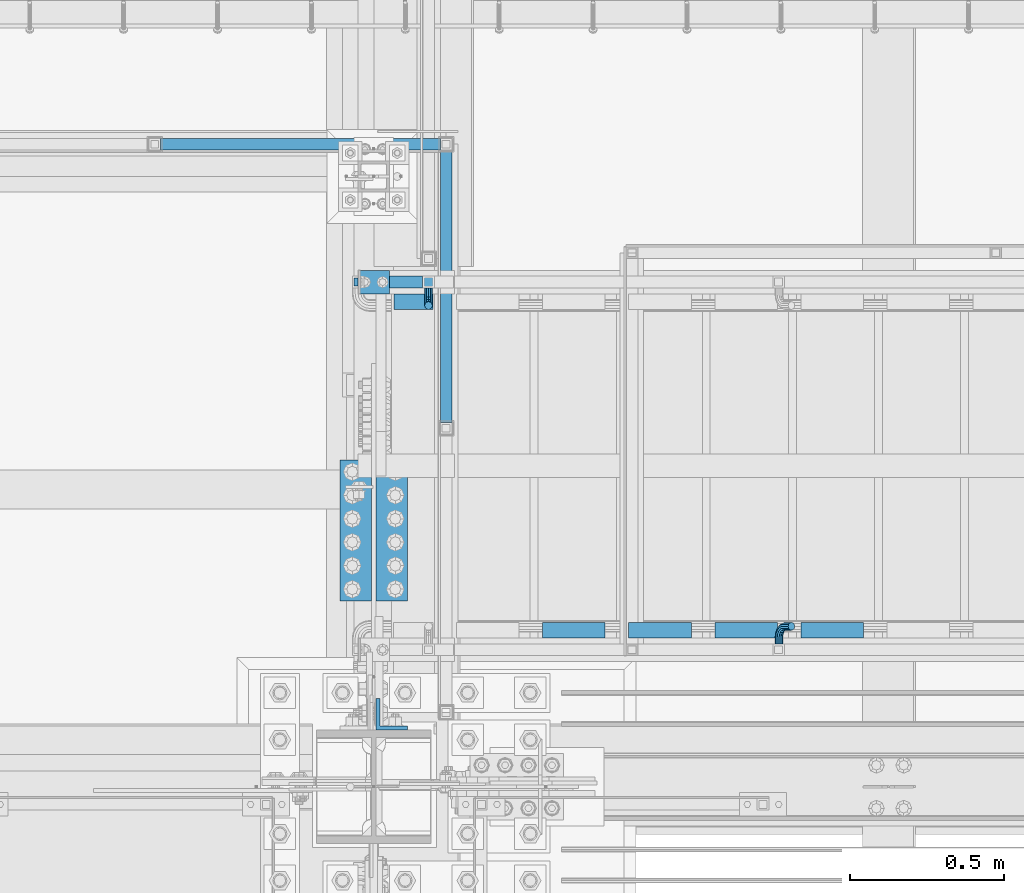
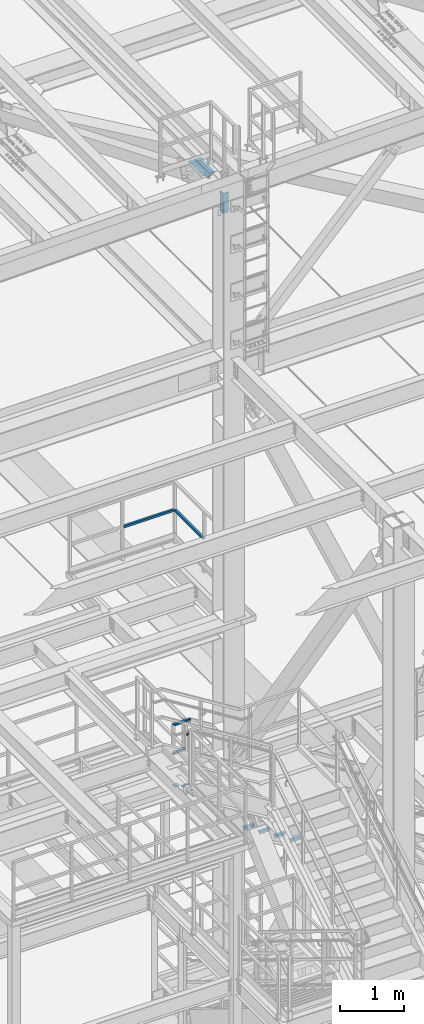
# One storey, part 2131 of 3843: 15 beams, 5 elements without a shape of their own.
"""IFC2X3 building model written with IfcOpenShell, lengths in millimetres."""

from ifc_helpers import new_model, si_unit, frame, origin_with_axes, place, context, subcontext, project, spatial, faceted_brep, material, type_object, element, aggregate, save


model = new_model("IFC2X3")

# Units and contexts
model_context = context("Model", 3, precision=1e-05, world=origin_with_axes())
body_context = subcontext(model_context, "Body", "Model", "MODEL_VIEW")
ifc_project = project(units=[si_unit("LENGTHUNIT", "METRE", prefix="MILLI"), si_unit("AREAUNIT", "SQUARE_METRE"), si_unit("VOLUMEUNIT", "CUBIC_METRE"), si_unit("MASSUNIT", "GRAM", prefix="KILO"), si_unit("TIMEUNIT", "SECOND"), si_unit("PLANEANGLEUNIT", "RADIAN"), si_unit("SOLIDANGLEUNIT", "STERADIAN"), si_unit("THERMODYNAMICTEMPERATUREUNIT", "DEGREE_CELSIUS"), si_unit("LUMINOUSINTENSITYUNIT", "LUMEN")], contexts=[model_context])

# Site, building, storey
site_placement = place(None, origin_with_axes())
site = spatial("IfcSite", under=ifc_project, at=site_placement, CompositionType="ELEMENT")
building_placement = place(site_placement, origin_with_axes())
building = spatial("IfcBuilding", under=site, at=building_placement, Name="Undefined", CompositionType="ELEMENT")
storey_placement = place(building_placement, origin_with_axes())
storey = spatial("IfcBuildingStorey", under=building, at=storey_placement, Name="Undefined", CompositionType="ELEMENT", Elevation=0.0)

# Assembly, beams
assembly_1_placement = place(storey_placement, origin_with_axes())
assembly_1 = element("IfcElementAssembly", 1, at=assembly_1_placement, inside=storey, Name="RAIL", AssemblyPlace="NOTDEFINED", PredefinedType="RIGID_FRAME")
ifc_material_1 = material()
beam_type_1 = type_object("IfcBeamType", Name="HSS1-1/2X1-1/2X1/4", PredefinedType="NOTDEFINED")
beam_1_placement = place(assembly_1_placement, frame((55219.6000061035, 27701.8747862042, 38099.9999983618), z_axis=(0.0, 0.0, 1.0), x_axis=(1.0, 0.0, 0.0)))
beam_1 = element("IfcBeam", 2, at=beam_1_placement, type_object=beam_type_1, material=ifc_material_1, Name="RAIL", ObjectType="HSS1-1/2X1-1/2X1/4", context=body_context, shape_type="Brep", body=[
    faceted_brep([(927.100006103494, -19.0499999999956, 19.0499992350015), (927.100006103494, -19.0499992350015, -19.0499992350015), (927.100006103494, 19.0499992350015, -19.0499992350015), (927.100006103494, 19.0499992350015, 19.0499992350015), (927.099999330007, -12.6999993299978, 12.6999993300014), (927.099999330007, 12.6999993299978, 12.6999993300014), (927.099999330007, 12.6999993299978, -12.6999993300014), (927.099999330007, -12.6999993299978, -12.6999993300014), (19.0499992350015, 19.0499992350015, -19.0499992350015), (19.0499992350015, 19.0499992350015, 19.0499992350015), (19.0499992350015, -19.0499992350015, 19.0499992350015), (19.0499992350015, -19.0499992350015, -19.0499992350015), (19.0499992350015, 12.6999993299978, 12.6999993299978), (19.0499992350015, -12.6999993299978, 12.6999993299978), (19.0499992350015, -12.6999993299978, -12.6999993299978), (19.0499992350015, 12.6999993299978, -12.6999993299978)], [[[0, 1, 2, 3], [4, 5, 6, 7]], [[8, 9, 3, 2]], [[9, 10, 0, 3]], [[10, 11, 1, 0]], [[11, 8, 2, 1]], [[11, 10, 9, 8], [12, 13, 14, 15]], [[14, 13, 4, 7]], [[15, 14, 7, 6]], [[12, 15, 6, 5]], [[13, 12, 5, 4]]]),
])
beam_2_placement = place(assembly_1_placement, frame((56165.7500122069, 26779.5373931012, 38099.9999983618), z_axis=(0.0, 0.0, 1.0), x_axis=(0.0, 1.0, 0.0)))
beam_2 = element("IfcBeam", 3, at=beam_2_placement, type_object=beam_type_1, material=ifc_material_1, Name="RAIL", ObjectType="HSS1-1/2X1-1/2X1/4", context=body_context, shape_type="Brep", body=[
    faceted_brep([(903.287393102968, -19.0500000001557, 19.0499992350015), (903.287393102968, -19.0499992350015, -19.0499992350015), (903.287393102968, 19.0499992350015, -19.0499992350015), (903.287393102968, 19.0499992350015, 19.0499992350015), (903.287393102968, -12.6999993299978, 12.6999993299978), (903.287393102968, 12.6999993299978, 12.6999993299978), (903.287393102968, 12.6999993299978, -12.6999993299978), (903.287393102968, -12.6999993299978, -12.6999993299978), (19.0499992350015, 19.0499992350015, -19.0499992350015), (19.0499992350015, 19.0499992350015, 19.0499992350015), (19.0499992350015, -19.0499992350015, 19.0499992350015), (19.0499992350015, -19.0499992350015, -19.0499992350015), (19.0499992350015, 12.6999993299978, 12.6999993299978), (19.0499992350015, -12.6999993299978, 12.6999993299978), (19.0499992350015, -12.6999993299978, -12.6999993299978), (19.0499992350015, 12.6999993299978, -12.6999993299978)], [[[0, 1, 2, 3], [4, 5, 6, 7]], [[8, 9, 3, 2]], [[9, 10, 0, 3]], [[10, 11, 1, 0]], [[11, 8, 2, 1]], [[11, 10, 9, 8], [12, 13, 14, 15]], [[14, 13, 4, 7]], [[15, 14, 7, 6]], [[12, 15, 6, 5]], [[13, 12, 5, 4]]]),
])
aggregate(assembly_1, [beam_1, beam_2])

assembly_2_placement = place(storey_placement, origin_with_axes())
assembly_2 = element("IfcElementAssembly", 4, at=assembly_2_placement, inside=storey, Name="RAIL", AssemblyPlace="NOTDEFINED", PredefinedType="RIGID_FRAME")
beam_3_placement = place(assembly_2_placement, frame((56108.5999999771, 27254.20000005, 33832.8000002553), z_axis=(0.0, 0.0, 1.0), x_axis=(-1.0, 0.0, 0.0)))
beam_3 = element("IfcBeam", 5, at=beam_3_placement, type_object=beam_type_1, material=ifc_material_1, Name="RAIL", ObjectType="HSS1-1/2X1-1/2X1/4", context=body_context, shape_type="Brep", body=[
    faceted_brep([(19.0499992350015, -19.0499992350015, -19.0499992350015), (19.0499992350015, -19.0499992350015, 19.0499992350015), (19.0499992350015, 19.0499992350015, 19.0499992350015), (19.0499992350015, 19.0499992350015, -19.0499992350015), (19.0499992350015, 12.6999993299978, 12.6999993299978), (19.0499992350015, -12.6999993299978, 12.6999993299978), (19.0499992350015, -12.6999993299978, -12.6999993299978), (19.0499992350015, 12.6999993299978, -12.6999993299978), (247.649999996247, 19.0499992350015, -19.0499992350015), (247.649999996247, -19.0499992350015, -19.0499992350015), (209.550000745963, -19.0499992350015, 19.0499992356708), (209.550000745963, 19.0499992350015, 19.0499992356708), (215.900000654663, -12.6999993300014, 12.6999993306963), (215.900000654663, 12.6999993300014, 12.6999993306963), (241.299999329458, 12.6999993300014, -12.6999993292266), (241.299999329458, -12.6999993300014, -12.6999993292266)], [[[0, 1, 2, 3], [4, 5, 6, 7]], [[8, 9, 0, 3]], [[9, 10, 1, 0]], [[10, 11, 2, 1]], [[11, 8, 3, 2]], [[10, 9, 8, 11], [12, 13, 14, 15]], [[13, 12, 5, 4]], [[14, 13, 4, 7]], [[15, 14, 7, 6]], [[12, 15, 6, 5]]]),
])
beam_4_placement = place(assembly_2_placement, frame((55879.9999999771, 27254.20000005, 34366.20000008), z_axis=(0.0, 0.0, -1.0), x_axis=(1.0, 0.0, 0.0)))
beam_4 = element("IfcBeam", 6, at=beam_4_placement, type_object=beam_type_1, material=ifc_material_1, Name="RAIL", ObjectType="HSS1-1/2X1-1/2X1/4", context=body_context, shape_type="Brep", body=[
    faceted_brep([(-12.6999993309546, 12.6999993299978, -12.6999993299978), (-12.6999993309546, -12.6999993299978, -12.6999993299978), (308.4703350696, -12.6999993300014, -12.6999993290228), (308.4703350696, 12.6999993300014, -12.6999993290228), (12.6999993290483, -12.6999993299978, 12.6999993299978), (301.129664099179, -12.6999993300014, 12.6999993309582), (12.6999993290483, 12.6999993299978, 12.6999993299978), (301.129664099179, 12.6999993300014, 12.6999993309582), (-19.0499992359546, 19.0499992350015, -19.0499992350015), (19.0499992350015, 19.0499992350015, 19.0499992350015), (299.294496287221, 19.0499992350015, 19.0499992359473), (310.305502881565, 19.0499992350015, -19.0499992340192), (19.0499992350015, -19.0499992350015, 19.0499992350015), (299.294496287221, -19.0499992350015, 19.0499992359473), (-19.0499992359546, -19.0499992350015, -19.0499992350015), (310.305502881565, -19.0499992350015, -19.0499992340192)], [[[0, 1, 2, 3]], [[1, 4, 5, 2]], [[4, 6, 7, 5]], [[6, 0, 3, 7]], [[8, 9, 10, 11]], [[9, 12, 13, 10]], [[12, 14, 15, 13]], [[14, 8, 11, 15]], [[13, 15, 11, 10], [5, 7, 3, 2]], [[14, 12, 9, 8], [6, 4, 1, 0]]]),
])

assembly_3_placement = place(storey_placement, origin_with_axes())
assembly_3 = element("IfcElementAssembly", 7, at=assembly_3_placement, inside=storey, Name="STAIR", AssemblyPlace="NOTDEFINED", PredefinedType="RIGID_FRAME")
ifc_material_2 = material(Name="STEEL/A36")
beam_type_2 = type_object("IfcBeamType", PredefinedType="NOTDEFINED")
beam_5_placement = place(assembly_3_placement, frame((55880.0, 27254.2, 33200.9749999995), z_axis=(0.0, 1.0, 0.0), x_axis=(1.0, 0.0, 0.0)))
beam_5 = element("IfcBeam", 8, at=beam_5_placement, type_object=beam_type_2, material=ifc_material_2, Name="PLATE", context=body_context, shape_type="Brep", body=[
    faceted_brep([(0.0, 3.17500000000291, -38.0999999999985), (0.0, 3.17500000000291, 38.0999999999985), (101.60000000002, 3.17500000000291, 38.0999999999985), (101.60000000002, 3.17500000000291, -38.0999999999985), (0.0, -3.17500000000291, 38.0999999999985), (101.60000000002, -3.17500000000291, 38.0999999999985), (0.0, -3.17500000000291, -38.0999999999985), (101.60000000002, -3.17500000000291, -38.0999999999985)], [[[0, 1, 2, 3]], [[1, 4, 5, 2]], [[4, 6, 7, 5]], [[6, 0, 3, 7]], [[5, 7, 3, 2]], [[6, 4, 1, 0]]]),
])
beam_type_3 = type_object("IfcBeamType", Name="L2X2X3/16", PredefinedType="NOTDEFINED")
beam_6_placement = place(assembly_3_placement, frame((55995.8875, 27190.7000000424, 33178.7500000177), z_axis=(0.0, -1.0, 0.0), x_axis=(1.0, 0.0, 0.0)))
beam_6 = element("IfcBeam", 9, at=beam_6_placement, type_object=beam_type_3, material=ifc_material_2, Name="ANGLE", ObjectType="L2X2X3/16", context=body_context, shape_type="Brep", body=[
    faceted_brep([(0.0, 25.4000000000015, -25.4000000000015), (0.0, 25.4000000000015, 25.4000000000015), (127.000000013548, 25.4000000000015, 25.4000000000015), (127.000000013548, 25.4000000000015, -25.4000000000015), (0.0, 20.6375000000007, 25.4000000000015), (127.000000013548, 20.6374999999971, 25.4000000000015), (0.0, 20.6375000000007, -20.6375000000007), (127.000000013548, 20.6374999999971, -20.6375000000007), (0.0, -25.4000000000015, -20.6375000000007), (127.000000013548, -25.4000000000015, -20.6375000000007), (0.0, -25.4000000000015, -25.4000000000015), (127.000000013548, -25.4000000000015, -25.4000000000015)], [[[0, 1, 2, 3]], [[1, 4, 5, 2]], [[4, 6, 7, 5]], [[6, 8, 9, 7]], [[8, 10, 11, 9]], [[10, 0, 3, 11]], [[5, 7, 9, 11, 3, 2]], [[10, 8, 6, 4, 1, 0]]]),
])
beam_7_placement = place(assembly_3_placement, frame((56682.2696627235, 26123.9000000591, 32867.599999978), z_axis=(0.0, 1.0, 0.0), x_axis=(-1.0, 0.0, 0.0)))
beam_7 = element("IfcBeam", 10, at=beam_7_placement, type_object=beam_type_3, material=ifc_material_2, Name="ANGLE", ObjectType="L2X2X3/16", context=body_context, shape_type="Brep", body=[
    faceted_brep([(0.0, 25.4000000000015, -25.4000000000015), (0.0, 25.4000000000015, 25.4000000000015), (203.199999999997, 25.4000000000015, 25.4000000000015), (203.199999999997, 25.4000000000015, -25.4000000000015), (0.0, 20.6375000000007, 25.4000000000015), (203.199999999997, 20.6375000000007, 25.4000000000015), (0.0, 20.6375000000007, -20.6375000000007), (203.199999999997, 20.6375000000007, -20.6375000000007), (0.0, -25.4000000000015, -20.6375000000007), (203.199999999997, -25.4000000000015, -20.6375000000007), (0.0, -25.4000000000015, -25.4000000000015), (203.199999999997, -25.4000000000015, -25.4000000000015)], [[[0, 1, 2, 3]], [[1, 4, 5, 2]], [[4, 6, 7, 5]], [[6, 8, 9, 7]], [[8, 10, 11, 9]], [[10, 0, 3, 11]], [[5, 7, 9, 11, 3, 2]], [[10, 8, 6, 4, 1, 0]]]),
])
beam_8_placement = place(assembly_3_placement, frame((56961.6696627235, 26123.9000000571, 32691.387499978), z_axis=(0.0, 1.0, 0.0), x_axis=(-1.0, 0.0, 0.0)))
beam_8 = element("IfcBeam", 11, at=beam_8_placement, type_object=beam_type_3, material=ifc_material_2, Name="ANGLE", ObjectType="L2X2X3/16", context=body_context, shape_type="Brep", body=[
    faceted_brep([(0.0, 25.4000000000015, -25.4000000000015), (0.0, 25.4000000000015, 25.4000000000015), (203.199999999997, 25.4000000000015, 25.4000000000015), (203.199999999997, 25.4000000000015, -25.4000000000015), (0.0, 20.6375000000007, 25.4000000000015), (203.199999999997, 20.6375000000007, 25.4000000000015), (0.0, 20.6375000000007, -20.6375000000007), (203.199999999997, 20.6375000000007, -20.6375000000007), (0.0, -25.4000000000015, -20.6375000000007), (203.199999999997, -25.4000000000015, -20.6375000000007), (0.0, -25.4000000000015, -25.4000000000015), (203.199999999997, -25.4000000000015, -25.4000000000015)], [[[0, 1, 2, 3]], [[1, 4, 5, 2]], [[4, 6, 7, 5]], [[6, 8, 9, 7]], [[8, 10, 11, 9]], [[10, 0, 3, 11]], [[5, 7, 9, 11, 3, 2]], [[10, 8, 6, 4, 1, 0]]]),
])
beam_9_placement = place(assembly_3_placement, frame((57241.0696627235, 26123.900000055, 32515.174999978), z_axis=(0.0, 1.0, 0.0), x_axis=(-1.0, 0.0, 0.0)))
beam_9 = element("IfcBeam", 12, at=beam_9_placement, type_object=beam_type_3, material=ifc_material_2, Name="ANGLE", ObjectType="L2X2X3/16", context=body_context, shape_type="Brep", body=[
    faceted_brep([(0.0, 25.4000000000015, -25.4000000000015), (0.0, 25.4000000000015, 25.4000000000015), (203.199999999997, 25.4000000000015, 25.4000000000015), (203.199999999997, 25.4000000000015, -25.4000000000015), (0.0, 20.6375000000007, 25.4000000000015), (203.199999999997, 20.6375000000007, 25.4000000000015), (0.0, 20.6375000000007, -20.6375000000007), (203.199999999997, 20.6375000000007, -20.6375000000007), (0.0, -25.4000000000015, -20.6375000000007), (203.199999999997, -25.4000000000015, -20.6375000000007), (0.0, -25.4000000000015, -25.4000000000015), (203.199999999997, -25.4000000000015, -25.4000000000015)], [[[0, 1, 2, 3]], [[1, 4, 5, 2]], [[4, 6, 7, 5]], [[6, 8, 9, 7]], [[8, 10, 11, 9]], [[10, 0, 3, 11]], [[5, 7, 9, 11, 3, 2]], [[10, 8, 6, 4, 1, 0]]]),
])
beam_10_placement = place(assembly_3_placement, frame((57520.4696627267, 26123.9000000536, 32338.9624999776), z_axis=(0.0, 1.0, 0.0), x_axis=(-1.0, 0.0, 0.0)))
beam_10 = element("IfcBeam", 13, at=beam_10_placement, type_object=beam_type_3, material=ifc_material_2, Name="ANGLE", ObjectType="L2X2X3/16", context=body_context, shape_type="Brep", body=[
    faceted_brep([(0.0, 25.4000000000015, -25.4000000000015), (0.0, 25.4000000000015, 25.4000000000015), (203.199999999997, 25.4000000000015, 25.4000000000015), (203.199999999997, 25.4000000000015, -25.4000000000015), (0.0, 20.6375000000007, 25.4000000000015), (203.199999999997, 20.6375000000007, 25.4000000000015), (0.0, 20.6375000000007, -20.6375000000007), (203.199999999997, 20.6375000000007, -20.6375000000007), (0.0, -25.4000000000015, -20.6375000000007), (203.199999999997, -25.4000000000015, -20.6375000000007), (0.0, -25.4000000000015, -25.4000000000015), (203.199999999997, -25.4000000000015, -25.4000000000015)], [[[0, 1, 2, 3]], [[1, 4, 5, 2]], [[4, 6, 7, 5]], [[6, 8, 9, 7]], [[8, 10, 11, 9]], [[10, 0, 3, 11]], [[5, 7, 9, 11, 3, 2]], [[10, 8, 6, 4, 1, 0]]]),
])
aggregate(assembly_3, [beam_6, beam_5, beam_7, beam_8, beam_9, beam_10])

# Beam
beam_type_4 = type_object("IfcBeamType", PredefinedType="NOTDEFINED")
beam_11_placement = place(assembly_2_placement, frame((56108.6000003381, 27235.15000005, 34118.55), z_axis=(-1.0, 0.0, 0.0), x_axis=(0.0, -1.0, 0.0)))
beam_11 = element("IfcBeam", 14, at=beam_11_placement, type_object=beam_type_4, material=ifc_material_2, Name="BRACKET ARM", context=body_context, shape_type="Brep", body=[
    faceted_brep([(0.0, -12.6999999999971, 0.0), (0.0, -10.9985226280696, -6.34999999999854), (19.0500015258731, -10.9985226280623, -6.34999999999854), (19.0500015258731, -12.6999999999971, -6.33008312433958e-10), (0.0, -6.35000000000582, -10.9985226280623), (19.0500015258731, -6.34999999999854, -10.9985226280623), (0.0, 0.0, -12.6999999999971), (19.0500015258731, 0.0, -12.6999999999971), (0.0, 6.35000000000582, -10.9985226280623), (19.0500015258731, 6.34999999999854, -10.9985226280623), (0.0, 10.9985226280696, -6.34999999999854), (19.0500015258731, 10.9985226280623, -6.34999999999854), (0.0, 12.6999999999971, 0.0), (19.0500015258731, 12.6999999999971, 0.0), (0.0, 10.9985226280696, 6.34999999999854), (19.0500015258731, 10.9985226280623, 6.34999999999854), (0.0, 6.35000000000582, 10.9985226280623), (19.0500015258731, 6.34999999999854, 10.9985226280623), (0.0, 0.0, 12.6999999999971), (19.0500015258731, 0.0, 12.6999999999971), (0.0, -6.35000000000582, 10.9985226280623), (19.0500015258731, -6.34999999999854, 10.9985226280623), (0.0, -10.9985226280696, 6.34999999999854), (19.0500015258731, -10.9985226280623, 6.34999999999854), (38.4903193060891, -8.8330803677236, -3.34694050252438e-10), (37.8391921052389, -7.26112024908798, 6.34999999974389), (36.0602795104642, -2.96644533684594, 10.9985226280041), (33.6302397149266, 2.90018969451194, 12.7000000002226), (31.2001999194181, 8.76682472604443, 10.9985226285644), (29.4212873247307, 13.061499638774, 6.35000000070431), (28.7701601240115, 14.6334597580644, 7.78527464717627e-10), (29.4212873248762, 13.0614996394288, -6.34999999929278), (31.2001999196509, 8.76682472718676, -10.9985226275603), (33.6302397151885, 2.90018969582889, -12.6999999997788), (36.0602795106824, -2.96644533571089, -10.9985226281206), (37.8391921053699, -7.26112024843314, -6.35000000026048), (53.7678987435793, 3.38210125690239, -6.3499999994383), (54.9710249311902, 2.17897506880399, 5.0931703299284e-10), (50.4808968708676, 6.66910312997061, -10.9985226273784), (45.9907688103704, 11.1592311906061, -12.6999999991458), (41.5006407498004, 15.6493592510378, -10.9985226270364), (38.213638876914, 18.9363611235749, -6.34999999884167), (37.0105126890558, 20.1394873109457, 1.20053300634027e-09), (38.2136388766667, 18.9363611228473, 6.35000000115542), (41.5006407493784, 15.6493592497718, 10.9985226290883), (45.9907688098756, 11.1592311891436, 12.7000000008557), (50.4808968704456, 6.66910312870459, 10.9985226287463), (53.7678987433319, 3.38210125617479, 6.35000000055879), (64.4111202489148, 19.3108078951118, -6.34999999821594), (65.9830803677178, 18.6596806939051, 1.77533365786076e-09), (60.1164453365491, 21.0897204901557, -10.9985226262725), (54.2498103051475, 23.5197602857806, -12.6999999981927), (48.3831752736587, 25.9498000811873, -10.9985226262434), (44.0885003610601, 27.7287126756128, -6.34999999817228), (42.516540241937, 28.3798398759754, 1.83354131877422e-09), (44.08850036074, 27.7287126747688, 6.35000000183209), (48.3831752731057, 25.9498000797321, 10.9985226298813), (54.2498103045073, 23.5197602840999, 12.7000000018088), (60.1164453359961, 21.0897204886933, 10.9985226298522), (64.4111202485947, 19.3108078942678, 6.35000000178115), (68.1485226282239, 38.0999984746086, -6.3499999967753), (69.8499999999913, 38.0999984741211, 2.92493496090174e-09), (63.500000000291, 38.0999984749651, -10.9985226249628), (57.1500000003434, 38.0999984750961, -12.6999999970722), (50.8000000002939, 38.0999984749651, -10.998522625312), (46.1514773720992, 38.0999984746086, -6.34999999737192), (44.4499999999971, 38.0999984741211, 2.58296495303512e-09), (46.1514773717645, 38.0999984736336, 6.35000000262517), (50.7999999996973, 38.0999984732771, 10.9985226308127), (57.1499999996449, 38.0999984731461, 12.700000002922), (63.4999999996944, 38.0999984732771, 10.9985226311619), (68.1485226278892, 38.0999984736336, 6.35000000322179), (68.1485226280638, 76.2000000002372, -6.34999999414867), (69.8499999999913, 76.199999999757, 5.84986992180347e-09), (63.5, 76.200000000601, -10.9985226222125), (57.1499999999942, 76.2000000007247, -12.6999999941472), (50.7999999999884, 76.200000000601, -10.9985226222125), (46.1514773719246, 76.2000000002372, -6.34999999414867), (44.4499999999971, 76.199999999757, 5.84986992180347e-09), (46.1514773719246, 76.1999999992695, 6.35000000584841), (50.7999999999884, 76.1999999989057, 10.9985226339122), (57.1499999999942, 76.199999998782, 12.700000005847), (63.5, 76.1999999989057, 10.9985226339122), (68.1485226280638, 76.1999999992695, 6.35000000584841)], [[[0, 1, 2, 3]], [[1, 4, 5, 2]], [[4, 6, 7, 5]], [[6, 8, 9, 7]], [[8, 10, 11, 9]], [[10, 12, 13, 11]], [[12, 14, 15, 13]], [[14, 16, 17, 15]], [[16, 18, 19, 17]], [[18, 20, 21, 19]], [[20, 22, 23, 21]], [[22, 0, 3, 23]], [[22, 20, 18, 16, 14, 12, 10, 8, 6, 4, 1, 0]], [[23, 3, 24, 25]], [[21, 23, 25, 26]], [[19, 21, 26, 27]], [[17, 19, 27, 28]], [[15, 17, 28, 29]], [[13, 15, 29, 30]], [[11, 13, 30, 31]], [[9, 11, 31, 32]], [[7, 9, 32, 33]], [[5, 7, 33, 34]], [[2, 5, 34, 35]], [[3, 2, 35, 24]], [[35, 36, 37, 24]], [[34, 38, 36, 35]], [[33, 39, 38, 34]], [[32, 40, 39, 33]], [[31, 41, 40, 32]], [[30, 42, 41, 31]], [[29, 43, 42, 30]], [[28, 44, 43, 29]], [[27, 45, 44, 28]], [[26, 46, 45, 27]], [[25, 47, 46, 26]], [[24, 37, 47, 25]], [[36, 48, 49, 37]], [[38, 50, 48, 36]], [[39, 51, 50, 38]], [[40, 52, 51, 39]], [[41, 53, 52, 40]], [[42, 54, 53, 41]], [[43, 55, 54, 42]], [[44, 56, 55, 43]], [[45, 57, 56, 44]], [[46, 58, 57, 45]], [[47, 59, 58, 46]], [[37, 49, 59, 47]], [[48, 60, 61, 49]], [[50, 62, 60, 48]], [[51, 63, 62, 50]], [[52, 64, 63, 51]], [[53, 65, 64, 52]], [[54, 66, 65, 53]], [[55, 67, 66, 54]], [[56, 68, 67, 55]], [[57, 69, 68, 56]], [[58, 70, 69, 57]], [[59, 71, 70, 58]], [[49, 61, 71, 59]], [[61, 60, 72, 73]], [[60, 62, 74, 72]], [[62, 63, 75, 74]], [[63, 64, 76, 75]], [[64, 65, 77, 76]], [[65, 66, 78, 77]], [[66, 67, 79, 78]], [[67, 68, 80, 79]], [[68, 69, 81, 80]], [[69, 70, 82, 81]], [[70, 71, 83, 82]], [[71, 61, 73, 83]], [[74, 75, 76, 77, 78, 79, 80, 81, 82, 83, 73, 72]]]),
])

aggregate(assembly_2, [beam_11, beam_3, beam_4])

# Assembly, beam
assembly_4_placement = place(storey_placement, origin_with_axes())
assembly_4 = element("IfcElementAssembly", 15, at=assembly_4_placement, inside=storey, Name="RAIL", AssemblyPlace="NOTDEFINED", PredefinedType="RIGID_FRAME")
beam_12_placement = place(assembly_4_placement, frame((57246.1530178774, 26079.45000005, 33431.8128442271), z_axis=(0.845831324935018, 0.0, -0.533450437959022), x_axis=(0.0, 1.0, 0.0)))
beam_12 = element("IfcBeam", 16, at=beam_12_placement, type_object=beam_type_4, material=ifc_material_2, Name="BRACKET ARM", context=body_context, shape_type="Brep", body=[
    faceted_brep([(0.0, -12.6999999999971, 0.0), (0.0, -10.9985226280696, -6.34999999999854), (19.0500015258731, -10.9985226280623, -6.34999999999854), (19.0500015258731, -12.6999999999971, -6.33008312433958e-10), (0.0, -6.35000000000582, -10.9985226280623), (19.0500015258731, -6.34999999999854, -10.9985226280623), (0.0, 0.0, -12.6999999999971), (19.0500015258731, 0.0, -12.6999999999971), (0.0, 6.35000000000582, -10.9985226280623), (19.0500015258731, 6.34999999999854, -10.9985226280623), (0.0, 10.9985226280696, -6.34999999999854), (19.0500015258731, 10.9985226280623, -6.34999999999854), (0.0, 12.6999999999971, 0.0), (19.0500015258731, 12.6999999999971, 0.0), (0.0, 10.9985226280696, 6.34999999999854), (19.0500015258731, 10.9985226280623, 6.34999999999854), (0.0, 6.35000000000582, 10.9985226280623), (19.0500015258731, 6.34999999999854, 10.9985226280623), (0.0, 0.0, 12.6999999999971), (19.0500015258731, 0.0, 12.6999999999971), (0.0, -6.35000000000582, 10.9985226280623), (19.0500015258731, -6.34999999999854, 10.9985226280623), (0.0, -10.9985226280696, 6.34999999999854), (19.0500015258731, -10.9985226280623, 6.34999999999854), (38.4903193060891, -8.8330803677236, -3.34694050252438e-10), (37.8391921052389, -7.26112024908798, 6.34999999974389), (36.0602795104642, -2.96644533684594, 10.9985226280041), (33.6302397149266, 2.90018969451194, 12.7000000002226), (31.2001999194181, 8.76682472604443, 10.9985226285644), (29.4212873247307, 13.061499638774, 6.35000000070431), (28.7701601240115, 14.6334597580644, 7.78527464717627e-10), (29.4212873248762, 13.0614996394288, -6.34999999929278), (31.2001999196509, 8.76682472718676, -10.9985226275603), (33.6302397151885, 2.90018969582889, -12.6999999997788), (36.0602795106824, -2.96644533571089, -10.9985226281206), (37.8391921053699, -7.26112024843314, -6.35000000026048), (53.7678987435793, 3.38210125690239, -6.3499999994383), (54.9710249311902, 2.17897506880399, 5.0931703299284e-10), (50.4808968708676, 6.66910312997061, -10.9985226273784), (45.9907688103704, 11.1592311906061, -12.6999999991458), (41.5006407498004, 15.6493592510378, -10.9985226270364), (38.213638876914, 18.9363611235749, -6.34999999884167), (37.0105126890558, 20.1394873109457, 1.20053300634027e-09), (38.2136388766667, 18.9363611228473, 6.35000000115542), (41.5006407493784, 15.6493592497718, 10.9985226290883), (45.9907688098756, 11.1592311891436, 12.7000000008557), (50.4808968704456, 6.66910312870459, 10.9985226287463), (53.7678987433319, 3.38210125617479, 6.35000000055879), (64.4111202489148, 19.3108078951118, -6.34999999821594), (65.9830803677178, 18.6596806939051, 1.77533365786076e-09), (60.1164453365491, 21.0897204901557, -10.9985226262725), (54.2498103051475, 23.5197602857806, -12.6999999981927), (48.3831752736587, 25.9498000811873, -10.9985226262434), (44.0885003610601, 27.7287126756128, -6.34999999817228), (42.516540241937, 28.3798398759754, 1.83354131877422e-09), (44.08850036074, 27.7287126747688, 6.35000000183209), (48.3831752731057, 25.9498000797321, 10.9985226298813), (54.2498103045073, 23.5197602840999, 12.7000000018088), (60.1164453359961, 21.0897204886933, 10.9985226298522), (64.4111202485947, 19.3108078942678, 6.35000000178115), (68.1485226282239, 38.0999984746086, -6.3499999967753), (69.8499999999913, 38.0999984741211, 2.92493496090174e-09), (63.500000000291, 38.0999984749651, -10.9985226249628), (57.1500000003434, 38.0999984750961, -12.6999999970722), (50.8000000002939, 38.0999984749651, -10.998522625312), (46.1514773720992, 38.0999984746086, -6.34999999737192), (44.4499999999971, 38.0999984741211, 2.58296495303512e-09), (46.1514773717645, 38.0999984736336, 6.35000000262517), (50.7999999996973, 38.0999984732771, 10.9985226308127), (57.1499999996449, 38.0999984731461, 12.700000002922), (63.4999999996944, 38.0999984732771, 10.9985226311619), (68.1485226278892, 38.0999984736336, 6.35000000322179), (68.1485226280638, 76.2000000002372, -6.34999999414867), (69.8499999999913, 76.199999999757, 5.84986992180347e-09), (63.5, 76.200000000601, -10.9985226222125), (57.1499999999942, 76.2000000007247, -12.6999999941472), (50.7999999999884, 76.200000000601, -10.9985226222125), (46.1514773719246, 76.2000000002372, -6.34999999414867), (44.4499999999971, 76.199999999757, 5.84986992180347e-09), (46.1514773719246, 76.1999999992695, 6.35000000584841), (50.7999999999884, 76.1999999989057, 10.9985226339122), (57.1499999999942, 76.199999998782, 12.700000005847), (63.5, 76.1999999989057, 10.9985226339122), (68.1485226280638, 76.1999999992695, 6.35000000584841)], [[[0, 1, 2, 3]], [[1, 4, 5, 2]], [[4, 6, 7, 5]], [[6, 8, 9, 7]], [[8, 10, 11, 9]], [[10, 12, 13, 11]], [[12, 14, 15, 13]], [[14, 16, 17, 15]], [[16, 18, 19, 17]], [[18, 20, 21, 19]], [[20, 22, 23, 21]], [[22, 0, 3, 23]], [[22, 20, 18, 16, 14, 12, 10, 8, 6, 4, 1, 0]], [[23, 3, 24, 25]], [[21, 23, 25, 26]], [[19, 21, 26, 27]], [[17, 19, 27, 28]], [[15, 17, 28, 29]], [[13, 15, 29, 30]], [[11, 13, 30, 31]], [[9, 11, 31, 32]], [[7, 9, 32, 33]], [[5, 7, 33, 34]], [[2, 5, 34, 35]], [[3, 2, 35, 24]], [[35, 36, 37, 24]], [[34, 38, 36, 35]], [[33, 39, 38, 34]], [[32, 40, 39, 33]], [[31, 41, 40, 32]], [[30, 42, 41, 31]], [[29, 43, 42, 30]], [[28, 44, 43, 29]], [[27, 45, 44, 28]], [[26, 46, 45, 27]], [[25, 47, 46, 26]], [[24, 37, 47, 25]], [[36, 48, 49, 37]], [[38, 50, 48, 36]], [[39, 51, 50, 38]], [[40, 52, 51, 39]], [[41, 53, 52, 40]], [[42, 54, 53, 41]], [[43, 55, 54, 42]], [[44, 56, 55, 43]], [[45, 57, 56, 44]], [[46, 58, 57, 45]], [[47, 59, 58, 46]], [[37, 49, 59, 47]], [[48, 60, 61, 49]], [[50, 62, 60, 48]], [[51, 63, 62, 50]], [[52, 64, 63, 51]], [[53, 65, 64, 52]], [[54, 66, 65, 53]], [[55, 67, 66, 54]], [[56, 68, 67, 55]], [[57, 69, 68, 56]], [[58, 70, 69, 57]], [[59, 71, 70, 58]], [[49, 61, 71, 59]], [[61, 60, 72, 73]], [[60, 62, 74, 72]], [[62, 63, 75, 74]], [[63, 64, 76, 75]], [[64, 65, 77, 76]], [[65, 66, 78, 77]], [[66, 67, 79, 78]], [[67, 68, 80, 79]], [[68, 69, 81, 80]], [[69, 70, 82, 81]], [[70, 71, 83, 82]], [[71, 61, 73, 83]], [[74, 75, 76, 77, 78, 79, 80, 81, 82, 83, 73, 72]]]),
])
aggregate(assembly_4, [beam_12])

# Assembly, beams
assembly_5_placement = place(storey_placement, origin_with_axes())
assembly_5 = element("IfcElementAssembly", 17, at=assembly_5_placement, inside=storey, Name="PLATE", AssemblyPlace="NOTDEFINED", PredefinedType="RIGID_FRAME")
ifc_material_3 = material(Name="STEEL/A572-50")
beam_type_5 = type_object("IfcBeamType", Name="L4X4X1/2", PredefinedType="NOTDEFINED")
beam_13_placement = place(assembly_5_placement, frame((55989.5375000077, 26676.3499999979, 45435.5160239227), z_axis=(0.0, 0.0, -1.0), x_axis=(0.0, -1.0, 0.0)))
beam_13 = element("IfcBeam", 18, at=beam_13_placement, type_object=beam_type_5, material=ifc_material_3, Name="ANGLE", ObjectType="L4X4X1/2", context=body_context, shape_type="Brep", body=[
    faceted_brep([(0.0, 50.8000000000029, -50.8000000000029), (0.0, 50.8000000000029, 50.8000000000029), (457.199999999997, 50.8000000000029, 50.8000000000029), (457.199999999997, 50.8000000000029, -50.8000000000029), (0.0, 38.0999999999985, 50.8000000000029), (457.199999999997, 38.0999999999985, 50.8000000000029), (0.0, 38.0999999999985, -38.0999999999985), (457.199999999997, 38.0999999999985, -38.0999999999985), (0.0, -50.8000000000029, -38.1000000000058), (457.199999999997, -50.8000000000029, -38.0999999999985), (0.0, -50.8000000000029, -50.8000000000029), (457.199999999997, -50.8000000000029, -50.8000000000029)], [[[0, 1, 2, 3]], [[1, 4, 5, 2]], [[4, 6, 7, 5]], [[6, 8, 9, 7]], [[8, 10, 11, 9]], [[10, 0, 3, 11]], [[5, 7, 9, 11, 3, 2]], [[10, 8, 6, 4, 1, 0]]]),
])
beam_14_placement = place(assembly_5_placement, frame((55872.0625000044, 26219.1499999992, 45435.516023916), z_axis=(0.0, 0.0, -1.0), x_axis=(0.0, 1.0, 0.0)))
beam_14 = element("IfcBeam", 19, at=beam_14_placement, type_object=beam_type_5, material=ifc_material_3, Name="ANGLE", ObjectType="L4X4X1/2", context=body_context, shape_type="Brep", body=[
    faceted_brep([(0.0, 50.8000000000029, -50.8000000000029), (0.0, 50.8000000000029, 50.8000000000029), (457.199999999997, 50.8000000000029, 50.8000000000029), (457.199999999997, 50.8000000000029, -50.8000000000029), (0.0, 38.0999999999985, 50.8000000000029), (457.199999999997, 38.0999999999985, 50.8000000000029), (0.0, 38.0999999999985, -38.0999999999985), (457.199999999997, 38.0999999999985, -38.0999999999985), (0.0, -50.8000000000029, -38.1000000000058), (457.199999999997, -50.8000000000029, -38.0999999999985), (0.0, -50.8000000000029, -50.8000000000029), (457.199999999997, -50.8000000000029, -50.8000000000029)], [[[0, 1, 2, 3]], [[1, 4, 5, 2]], [[4, 6, 7, 5]], [[6, 8, 9, 7]], [[8, 10, 11, 9]], [[10, 0, 3, 11]], [[5, 7, 9, 11, 3, 2]], [[10, 8, 6, 4, 1, 0]]]),
])
beam_15_placement = place(assembly_5_placement, frame((55989.5375, 25850.85, 45352.9660239119), z_axis=(0.0, 1.0, 0.0), x_axis=(0.0, 0.0, -1.0)))
beam_15 = element("IfcBeam", 20, at=beam_15_placement, type_object=beam_type_5, material=ifc_material_3, Name="ANGLE", ObjectType="L4X4X1/2", context=body_context, shape_type="Brep", body=[
    faceted_brep([(0.0, 50.8000000000029, -50.8000000000029), (0.0, 50.8000000000029, 50.8000000000029), (381.0, 50.8000000000029, 50.8000000000029), (381.0, 50.8000000000029, -50.8000000000029), (0.0, 38.0999999999985, 50.8000000000029), (381.0, 38.0999999999985, 50.8000000000029), (0.0, 38.0999999999985, -38.0999999999985), (381.0, 38.0999999999985, -38.1000000000058), (0.0, -50.8000000000029, -38.1000000000058), (381.0, -50.8000000000029, -38.1000000000058), (0.0, -50.8000000000029, -50.8000000000029), (381.0, -50.8000000000029, -50.8000000000029)], [[[0, 1, 2, 3]], [[1, 4, 5, 2]], [[4, 6, 7, 5]], [[6, 8, 9, 7]], [[8, 10, 11, 9]], [[10, 0, 3, 11]], [[5, 7, 9, 11, 3, 2]], [[10, 8, 6, 4, 1, 0]]]),
])
aggregate(assembly_5, [beam_13, beam_14, beam_15])

save(model, "model.ifc")
